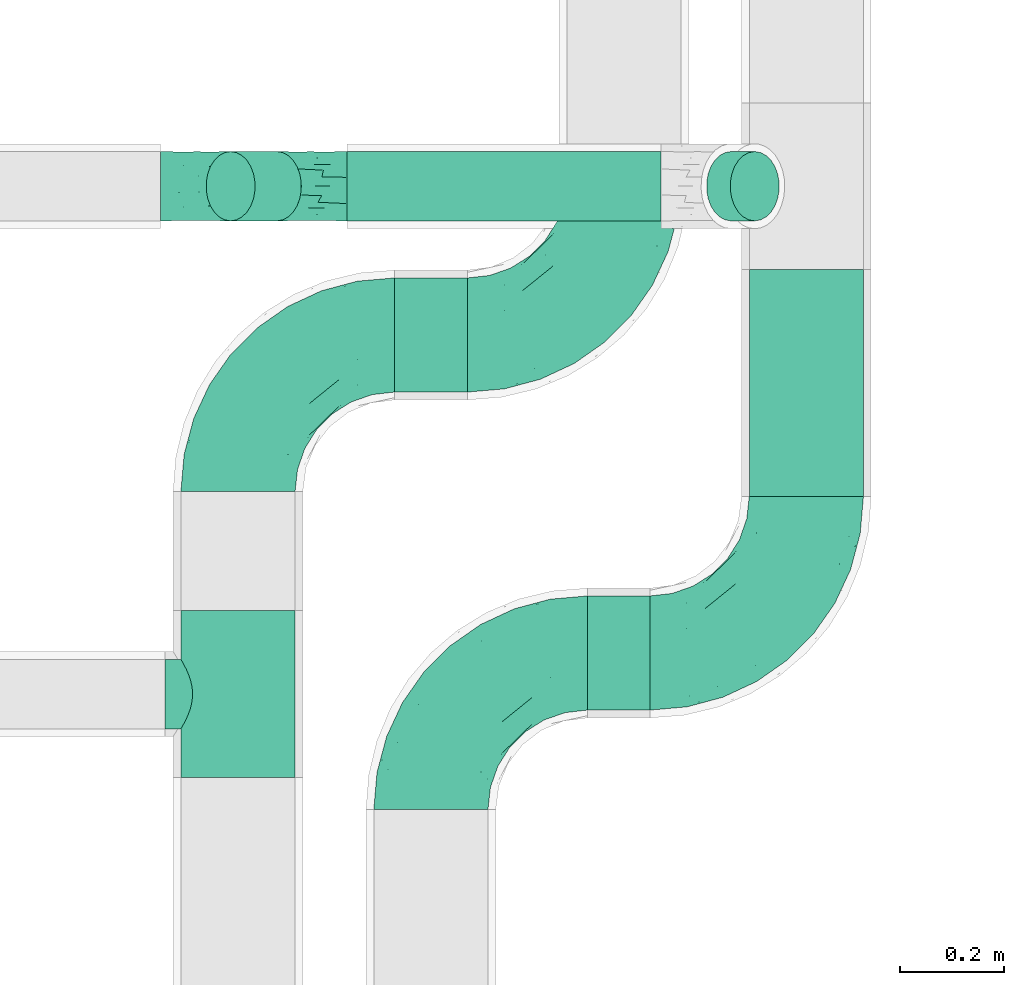
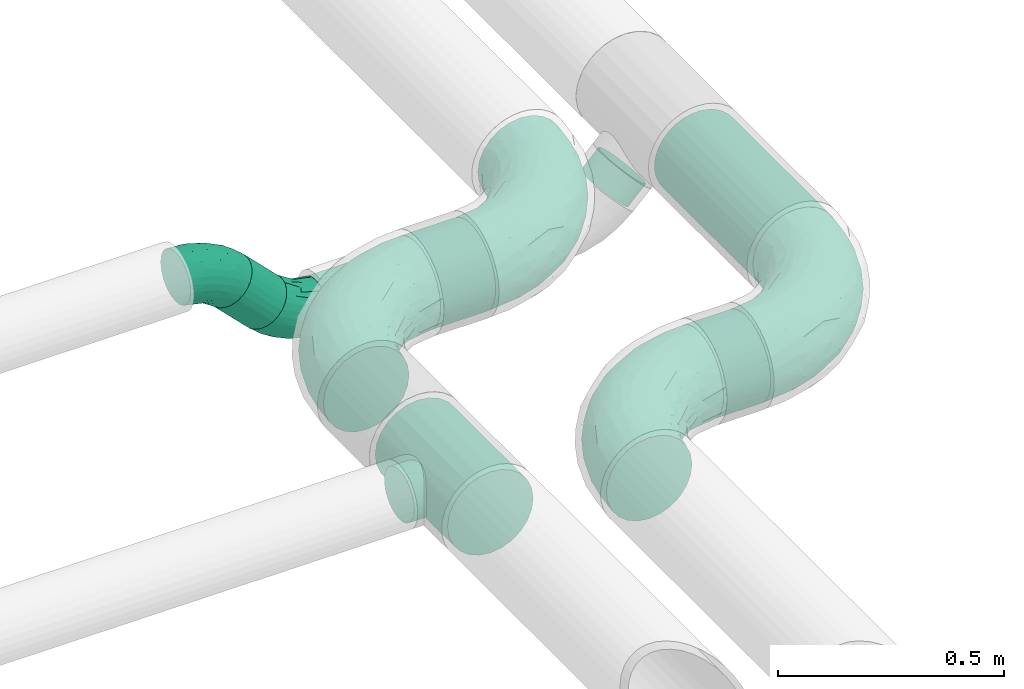
# One storey, part 73 of 93: 7 flow fittings, 6 flow segments.
"""IFC2X3 building model written with IfcOpenShell, lengths in millimetres."""

from ifc_helpers import new_model, entity, si_unit, converted_unit, derived_unit, direction, frame, origin, origin_2d_with_axis, place, context, subcontext, project, spatial, circle, extrude, faceted_brep, source, transform, mapped, material, type_object, type_shapes, element, save


model = new_model("IFC2X3")

# Units and contexts
model_context = context("Model", 3, precision=0.01, world=origin(), true_north=direction((6.12303176911189e-17, 1.0)))
body_context = subcontext(model_context, "Body", "Model", "MODEL_VIEW")
ifc_project = project(units=[si_unit("LENGTHUNIT", "METRE", prefix="MILLI"), si_unit("AREAUNIT", "SQUARE_METRE"), si_unit("VOLUMEUNIT", "CUBIC_METRE"), converted_unit("PLANEANGLEUNIT", "DEGREE", entity("IfcRatioMeasure", 0.0174532925199433), si_unit("PLANEANGLEUNIT", "RADIAN"), dimensions=[0, 0, 0, 0, 0, 0, 0]), si_unit("MASSUNIT", "GRAM", prefix="KILO"), derived_unit("MASSDENSITYUNIT", [(si_unit("MASSUNIT", "GRAM", prefix="KILO"), 1), (si_unit("LENGTHUNIT", "METRE"), -3)]), derived_unit("MOMENTOFINERTIAUNIT", [(si_unit("LENGTHUNIT", "METRE"), 4)]), si_unit("TIMEUNIT", "SECOND"), si_unit("FREQUENCYUNIT", "HERTZ"), si_unit("THERMODYNAMICTEMPERATUREUNIT", "DEGREE_CELSIUS"), derived_unit("THERMALTRANSMITTANCEUNIT", [(si_unit("MASSUNIT", "GRAM", prefix="KILO"), 1), (si_unit("THERMODYNAMICTEMPERATUREUNIT", "KELVIN"), -1), (si_unit("TIMEUNIT", "SECOND"), -3)]), derived_unit("VOLUMETRICFLOWRATEUNIT", [(si_unit("LENGTHUNIT", "METRE"), 3), (si_unit("TIMEUNIT", "SECOND"), -1)]), derived_unit("MASSFLOWRATEUNIT", [(si_unit("MASSUNIT", "GRAM", prefix="KILO"), 1), (si_unit("TIMEUNIT", "SECOND"), -1)]), derived_unit("ROTATIONALFREQUENCYUNIT", [(si_unit("TIMEUNIT", "SECOND"), -1)]), si_unit("ELECTRICCURRENTUNIT", "AMPERE"), si_unit("ELECTRICVOLTAGEUNIT", "VOLT"), si_unit("POWERUNIT", "WATT"), si_unit("FORCEUNIT", "NEWTON", prefix="KILO"), si_unit("ILLUMINANCEUNIT", "LUX"), si_unit("LUMINOUSFLUXUNIT", "LUMEN"), si_unit("LUMINOUSINTENSITYUNIT", "CANDELA"), derived_unit("USERDEFINED", [(si_unit("MASSUNIT", "GRAM", prefix="KILO"), -1), (si_unit("LENGTHUNIT", "METRE"), -2), (si_unit("TIMEUNIT", "SECOND"), 3), (si_unit("LUMINOUSFLUXUNIT", "LUMEN"), 1)]), derived_unit("LINEARVELOCITYUNIT", [(si_unit("LENGTHUNIT", "METRE"), 1), (si_unit("TIMEUNIT", "SECOND"), -1)]), si_unit("PRESSUREUNIT", "PASCAL"), derived_unit("USERDEFINED", [(si_unit("LENGTHUNIT", "METRE"), -2), (si_unit("MASSUNIT", "GRAM", prefix="KILO"), 1), (si_unit("TIMEUNIT", "SECOND"), -2)]), derived_unit("LINEARFORCEUNIT", [(si_unit("MASSUNIT", "GRAM", prefix="KILO"), 1), (si_unit("LENGTHUNIT", "METRE"), 1), (si_unit("TIMEUNIT", "SECOND"), -2), (si_unit("LENGTHUNIT", "METRE"), -1)]), derived_unit("PLANARFORCEUNIT", [(si_unit("MASSUNIT", "GRAM", prefix="KILO"), 1), (si_unit("LENGTHUNIT", "METRE"), 1), (si_unit("TIMEUNIT", "SECOND"), -2), (si_unit("LENGTHUNIT", "METRE"), -2)])], contexts=[model_context])

# Site, building, storey
site_placement = place(None, origin())
site = spatial("IfcSite", under=ifc_project, at=site_placement, CompositionType="ELEMENT")
building_placement = place(site_placement, origin())
building = spatial("IfcBuilding", under=site, at=building_placement, CompositionType="ELEMENT")
storey_placement = place(building_placement, frame((0.0, 0.0, -4200.0)))
storey = spatial("IfcBuildingStorey", under=building, at=storey_placement, CompositionType="ELEMENT", Elevation=-4200.0)

# Flow segments
pipe_segment_type = type_object("IfcPipeSegmentType", PredefinedType="NOTDEFINED")
flow_segment_1_placement = place(storey_placement, frame((31009.78, 8467.66, 2688.9)))
element("IfcFlowSegment", 1, at=flow_segment_1_placement, inside=storey, type_object=pipe_segment_type, context=body_context, shape_type="SweptSolid", body=[
    extrude(circle(Radius=109.5, at=origin_2d_with_axis()), frame((0.0, 111.1, 111.1), z_axis=(1.0, 0.0, 0.0), x_axis=(0.0, -1.0, 0.0)), (0.0, 0.0, 1.0), 120.218301649666),
])
flow_segment_2_placement = place(storey_placement, frame((30639.78, 9077.66, 2688.9)))
element("IfcFlowSegment", 2, at=flow_segment_2_placement, inside=storey, type_object=pipe_segment_type, context=body_context, shape_type="SweptSolid", body=[
    extrude(circle(Radius=109.5, at=origin_2d_with_axis()), frame((0.0, 111.1, 111.1), z_axis=(1.0, 0.0, 0.0), x_axis=(0.0, -1.0, 0.0)), (0.0, 0.0, 1.0), 140.218301649687),
])
flow_segment_3_placement = place(storey_placement, frame((31318.9, 8878.76, 2688.9)))
element("IfcFlowSegment", 3, at=flow_segment_3_placement, inside=storey, type_object=pipe_segment_type, context=body_context, shape_type="SweptSolid", body=[
    extrude(circle(Radius=109.5, at=origin_2d_with_axis()), frame((111.1, 0.0, 111.1), z_axis=(0.0, 1.0, 0.0), x_axis=(1.0, 0.0, 0.0)), (0.0, 0.0, 1.0), 435.378639737443),
])
flow_segment_4_placement = place(storey_placement, frame((30548.7, 9406.04, 2531.9)))
element("IfcFlowSegment", 4, at=flow_segment_4_placement, inside=storey, type_object=pipe_segment_type, context=body_context, shape_type="SweptSolid", body=[
    extrude(circle(Radius=66.5, at=origin_2d_with_axis()), frame((0.0, 68.1, 68.1), z_axis=(1.0, 0.0, 0.0), x_axis=(0.0, 1.0, 0.0)), (0.0, 0.0, 1.0), 602.598846298237),
])
flow_segment_5_placement = place(storey_placement, frame((31237.03, 9406.04, 2607.03)))
element("IfcFlowSegment", 5, at=flow_segment_5_placement, inside=storey, type_object=pipe_segment_type, context=body_context, shape_type="SweptSolid", body=[
    extrude(circle(Radius=66.5, at=origin_2d_with_axis()), frame((48.62, 68.1, 48.62), z_axis=(0.707106781186436, 0.0, 0.707106781186659), x_axis=(0.0, 1.0, 0.0)), (0.0, 0.0, 1.0), 64.1421356237339),
])
flow_segment_6_placement = place(storey_placement, frame((30277.03, 9406.04, 2607.03)))
element("IfcFlowSegment", 6, at=flow_segment_6_placement, inside=storey, type_object=pipe_segment_type, context=body_context, shape_type="SweptSolid", body=[
    extrude(circle(Radius=66.5, at=origin_2d_with_axis()), frame((137.32, 68.1, 48.62), z_axis=(-0.707106781186466, 0.0, 0.70710678118663), x_axis=(0.0, 1.0, 0.0)), (0.0, 0.0, 1.0), 125.44155877284),
])

# Flow fittings
ifc_material = material()
pipe_fitting_type_1 = type_object("IfcPipeFittingType", PredefinedType="NOTDEFINED", material=ifc_material)
shared_shape_1 = source(origin(), body_context, "Body", "Brep", [
    faceted_brep([(-300.0, 54.75, -94.83), (-300.0, 28.34, -105.77), (-300.0, 0.0, -109.5), (-300.0, -28.34, -105.77), (-300.0, -54.75, -94.83), (-300.0, -77.43, -77.43), (-300.0, -94.83, -54.75), (-300.0, -105.77, -28.34), (-300.0, -109.5, 0.0), (-300.0, -105.77, 28.34), (-300.0, -94.83, 54.75), (-300.0, -77.43, 77.43), (-300.0, -54.75, 94.83), (-300.0, -28.34, 105.77), (-300.0, 0.0, 109.5), (-300.0, 28.34, 105.77), (-300.0, 54.75, 94.83), (-300.0, 77.43, 77.43), (-300.0, 94.83, 54.75), (-300.0, 105.77, 28.34), (-300.0, 109.5, 0.0), (-300.0, 105.77, -28.34), (-300.0, 94.83, -54.75), (-300.0, 77.43, -77.43), (0.0, 300.0, -109.5), (-28.34, 300.0, -105.77), (-54.75, 300.0, -94.83), (-77.43, 300.0, -77.43), (-94.83, 300.0, -54.75), (-105.77, 300.0, -28.34), (-109.5, 300.0, 0.0), (-105.77, 300.0, 28.34), (-94.83, 300.0, 54.75), (-77.43, 300.0, 77.43), (-54.75, 300.0, 94.83), (-28.34, 300.0, 105.77), (0.0, 300.0, 109.5), (28.34, 300.0, 105.77), (54.75, 300.0, 94.83), (77.43, 300.0, 77.43), (94.83, 300.0, 54.75), (105.77, 300.0, 28.34), (109.5, 300.0, 0.0), (105.77, 300.0, -28.34), (94.83, 300.0, -54.75), (77.43, 300.0, -77.43), (54.75, 300.0, -94.83), (28.34, 300.0, -105.77), (-136.7, 192.11, 33.4), (-108.06, 242.04, 45.72), (-115.25, 243.91, 23.63), (-228.89, -103.28, 0.0), (-205.72, -93.9, 30.98), (-223.48, -82.05, 62.89), (82.05, 223.48, 62.89), (-220.42, -37.16, 99.17), (-129.13, -11.54, 94.5), (-142.05, 16.57, 106.73), (-36.78, -13.7, 0.0), (-12.01, 12.01, 21.92), (-70.11, -34.19, 28.86), (-251.45, -65.77, 85.04), (25.82, 74.91, 52.65), (64.71, 143.75, 51.25), (23.5, 97.93, 73.21), (-132.85, -71.12, 23.16), (-159.94, -84.8, 0.0), (-95.25, -54.64, 0.0), (-96.13, 227.29, 70.78), (-125.84, 193.4, 53.02), (-74.91, -25.82, 52.65), (-17.67, 17.67, 46.21), (-143.75, -64.71, 51.25), (34.19, 70.11, 28.86), (-36.83, 151.15, 109.47), (-72.47, 101.01, 109.48), (-16.57, 142.05, 106.73), (-230.69, 46.79, 102.89), (-151.06, 181.23, 0.0), (-193.02, 137.32, 30.03), (-245.74, 114.87, 22.86), (-217.35, 128.37, 0.0), (-257.61, 114.28, 0.0), (-206.97, 23.39, 109.2), (-228.54, -10.67, 107.88), (-63.53, 63.53, 103.95), (-152.02, 152.02, 61.3), (-239.14, 108.86, 45.92), (-46.79, 230.69, 102.89), (-23.39, 206.97, 109.2), (-187.96, -54.73, 82.5), (13.7, 36.78, 0.0), (54.64, 95.25, 0.0), (-252.51, 68.8, 88.87), (10.67, 228.54, 107.88), (37.16, 220.42, 99.17), (-156.91, 87.58, 100.32), (-167.17, 59.01, 106.65), (103.28, 228.89, 0.0), (93.9, 205.72, 30.98), (84.8, 159.94, 0.0), (-63.56, 159.75, 106.59), (71.12, 132.85, 23.16), (-142.71, 44.43, 109.5), (63.87, 170.82, 67.63), (65.77, 251.45, 85.04), (54.73, 187.96, 82.5), (11.54, 129.13, 94.5), (-114.28, 257.61, 0.0), (-128.37, 217.35, 0.0), (-181.23, 151.06, 0.0), (-229.13, 95.58, 70.67), (-69.3, 249.25, 89.01), (-87.17, 189.36, 91.52), (-119.64, 123.85, 98.47), (-114.16, 102.69, 105.6), (-97.93, -23.5, 73.21), (-38.98, 38.98, 84.91), (-76.05, 27.59, 96.01), (-136.12, 132.19, 87.79), (-194.78, 84.82, 91.29), (-38.49, 15.54, 67.27), (-119.57, 181.27, 70.23), (-177.11, 114.75, 77.16), (-196.39, 119.69, 59.32), (-29.77, 73.43, 96.01), (-68.81, 187.42, 100.76), (-170.82, -63.87, 67.63), (-242.04, 108.06, -45.72), (-243.91, 115.25, -23.63), (-99.47, 217.21, -71.36), (-202.49, 24.61, -109.22), (-224.29, -9.94, -107.83), (-12.01, 12.01, -21.92), (34.19, 70.11, -28.86), (-243.92, 70.22, -89.23), (-224.05, 97.15, -70.96), (-70.11, -34.19, -28.86), (37.16, 220.42, -99.17), (-137.32, 193.02, -30.03), (-192.11, 136.7, -33.4), (-9.56, 157.76, -106.97), (9.82, 126.4, -94.6), (-26.99, 75.01, -95.39), (-108.86, 239.14, -45.92), (-121.71, 195.15, -57.54), (-193.4, 125.84, -53.02), (-168.29, 120.23, -77.72), (-131.44, 156.1, -76.48), (-114.09, 152.67, -89.71), (-58.82, 66.26, -103.46), (-72.9, 29.97, -95.91), (-148.76, 21.01, -108.12), (-235.23, -39.46, -99.56), (-209.2, -59.7, -83.37), (25.86, 75.0, -52.68), (-17.67, 17.67, -46.21), (-224.25, -82.18, -62.93), (-205.72, -93.9, -30.98), (-160.57, -20.91, -97.48), (-111.76, -26.64, -77.85), (71.12, 132.85, -23.16), (64.71, 143.75, -51.25), (93.9, 205.72, -30.98), (-132.85, -71.12, -23.16), (23.46, 97.98, -73.28), (-39.51, 14.6, -67.27), (-157.82, 65.68, -106.39), (-100.24, 111.65, -106.5), (-108.02, 70.62, -109.5), (-229.63, 47.01, -102.91), (-77.16, -26.73, -53.6), (-143.75, -64.71, -51.25), (-114.87, 245.74, -22.86), (-21.27, 215.47, -109.15), (-65.44, 173.68, -104.22), (-44.92, 240.82, -102.64), (-152.02, 152.02, -61.3), (11.39, 233.1, -107.93), (65.77, 251.45, -85.04), (-72.39, 233.4, -89.67), (-38.98, 38.98, -84.91), (-52.88, 131.78, -109.49), (-180.51, 91.33, -91.9), (82.05, 223.48, -62.89), (54.73, 187.96, -82.5), (-153.65, 46.01, -109.28), (-131.22, 111.56, -98.89), (-160.99, -57.92, -70.28), (63.87, 170.82, -67.63)], [[[0, 1, 2, 3, 4, 5, 6, 7, 8, 9, 10, 11, 12, 13, 14, 15, 16, 17, 18, 19, 20, 21, 22, 23]], [[24, 25, 26, 27, 28, 29, 30, 31, 32, 33, 34, 35, 36, 37, 38, 39, 40, 41, 42, 43, 44, 45, 46, 47]], [[48, 49, 50]], [[9, 51, 52]], [[10, 53, 11]], [[9, 52, 10]], [[39, 54, 40]], [[55, 56, 57]], [[9, 8, 51]], [[58, 59, 60]], [[11, 61, 12]], [[62, 63, 64]], [[65, 66, 67]], [[68, 49, 69]], [[58, 60, 67]], [[52, 51, 66]], [[55, 12, 61]], [[70, 60, 71]], [[65, 72, 52]], [[71, 73, 62]], [[74, 75, 76]], [[77, 16, 15]], [[49, 31, 50]], [[78, 79, 48]], [[80, 81, 82]], [[14, 83, 15]], [[14, 13, 84]], [[75, 85, 76]], [[48, 79, 86]], [[80, 87, 79]], [[84, 13, 55]], [[20, 19, 80]], [[20, 80, 82]], [[35, 88, 89]], [[53, 90, 61]], [[91, 92, 73]], [[16, 93, 17]], [[87, 19, 18]], [[58, 91, 59]], [[89, 36, 35]], [[94, 95, 37]], [[96, 77, 97]], [[98, 99, 100]], [[101, 75, 74]], [[99, 98, 41]], [[102, 73, 92]], [[83, 103, 97]], [[94, 76, 95]], [[63, 73, 102]], [[99, 40, 54]], [[104, 63, 54]], [[105, 39, 38]], [[52, 72, 53]], [[65, 67, 60]], [[40, 99, 41]], [[42, 41, 98]], [[35, 34, 88]], [[106, 95, 107]], [[50, 30, 108]], [[109, 48, 50]], [[77, 15, 83]], [[78, 110, 79]], [[111, 17, 93]], [[95, 106, 105]], [[68, 33, 32]], [[48, 109, 78]], [[12, 55, 13]], [[89, 88, 101]], [[110, 81, 79]], [[112, 68, 113]], [[17, 111, 18]], [[114, 96, 115]], [[116, 117, 118]], [[112, 34, 33]], [[107, 64, 106]], [[96, 119, 120]], [[95, 38, 37]], [[73, 71, 59]], [[92, 100, 102]], [[121, 117, 116]], [[49, 32, 31]], [[68, 69, 122]], [[123, 120, 119]], [[124, 79, 87]], [[56, 55, 90]], [[84, 57, 83]], [[116, 56, 90]], [[56, 116, 118]], [[37, 36, 94]], [[107, 95, 76]], [[125, 76, 85]], [[107, 125, 64]], [[112, 88, 34]], [[114, 101, 126]], [[97, 77, 83]], [[93, 77, 120]], [[52, 53, 10]], [[127, 53, 72]], [[54, 39, 105]], [[99, 54, 63]], [[100, 99, 102]], [[63, 102, 99]], [[72, 65, 60]], [[52, 66, 65]], [[127, 116, 90]], [[72, 60, 70]], [[64, 117, 121]], [[104, 64, 63]], [[57, 84, 55]], [[83, 14, 84]], [[36, 89, 94]], [[94, 89, 74]], [[18, 111, 87]], [[124, 87, 111]], [[73, 59, 91]], [[60, 59, 71]], [[126, 101, 88]], [[101, 115, 75]], [[115, 97, 103]], [[75, 103, 85]], [[118, 57, 56]], [[85, 118, 125]], [[69, 49, 48]], [[68, 32, 49]], [[83, 57, 103]], [[96, 97, 115]], [[85, 103, 57]], [[115, 103, 75]], [[30, 50, 31]], [[109, 50, 108]], [[68, 112, 33]], [[112, 113, 126]], [[96, 114, 119]], [[77, 96, 120]], [[122, 113, 68]], [[86, 124, 123]], [[101, 114, 115]], [[113, 119, 114]], [[77, 93, 16]], [[111, 93, 120]], [[121, 70, 71]], [[72, 70, 116]], [[63, 62, 73]], [[121, 62, 64]], [[87, 80, 19]], [[81, 80, 79]], [[53, 61, 11]], [[55, 61, 90]], [[95, 105, 38]], [[54, 105, 106]], [[116, 127, 72]], [[90, 53, 127]], [[54, 106, 104]], [[64, 104, 106]], [[70, 121, 116]], [[121, 71, 62]], [[123, 124, 111]], [[79, 124, 86]], [[120, 123, 111]], [[86, 123, 119]], [[112, 126, 88]], [[114, 126, 113]], [[94, 74, 76]], [[101, 74, 89]], [[125, 118, 117]], [[57, 118, 85]], [[64, 125, 117]], [[76, 125, 107]], [[48, 86, 69]], [[69, 86, 122]], [[86, 119, 122]], [[113, 122, 119]], [[128, 21, 129]], [[130, 28, 27]], [[2, 1, 131]], [[2, 131, 132]], [[91, 133, 134]], [[0, 23, 135]], [[136, 23, 22]], [[58, 67, 137]], [[82, 129, 20]], [[46, 138, 47]], [[139, 110, 78]], [[129, 81, 140]], [[141, 142, 143]], [[140, 81, 110]], [[144, 145, 139]], [[136, 128, 146]], [[147, 148, 149]], [[150, 151, 152]], [[153, 154, 4]], [[155, 134, 156]], [[157, 158, 6]], [[5, 157, 6]], [[159, 151, 160]], [[8, 7, 51]], [[154, 5, 4]], [[161, 162, 163]], [[164, 137, 67]], [[2, 132, 3]], [[165, 155, 166]], [[7, 158, 51]], [[66, 51, 158]], [[159, 160, 154]], [[167, 168, 169]], [[137, 156, 133]], [[1, 0, 170]], [[140, 128, 129]], [[78, 109, 139]], [[171, 137, 172]], [[156, 137, 171]], [[144, 29, 28]], [[30, 173, 108]], [[174, 175, 176]], [[173, 30, 29]], [[177, 140, 139]], [[157, 5, 154]], [[173, 144, 139]], [[174, 25, 24]], [[170, 131, 1]], [[178, 24, 47]], [[46, 179, 138]], [[167, 131, 170]], [[25, 176, 26]], [[173, 109, 108]], [[27, 180, 130]], [[165, 181, 143]], [[150, 182, 141]], [[92, 161, 100]], [[134, 92, 91]], [[183, 135, 136]], [[3, 153, 4]], [[98, 100, 163]], [[138, 142, 141]], [[91, 58, 133]], [[179, 46, 45]], [[44, 43, 163]], [[163, 162, 184]], [[42, 98, 43]], [[172, 137, 164]], [[6, 158, 7]], [[43, 98, 163]], [[161, 92, 134]], [[45, 44, 184]], [[180, 27, 26]], [[184, 185, 179]], [[130, 180, 149]], [[139, 140, 110]], [[67, 66, 164]], [[131, 152, 132]], [[178, 174, 24]], [[182, 169, 168]], [[128, 22, 21]], [[147, 183, 136]], [[142, 138, 185]], [[178, 138, 141]], [[165, 142, 185]], [[142, 165, 143]], [[150, 143, 151]], [[182, 150, 169]], [[135, 170, 0]], [[186, 167, 169]], [[131, 186, 152]], [[153, 132, 159]], [[176, 180, 26]], [[187, 175, 168]], [[175, 149, 180]], [[149, 183, 147]], [[171, 166, 156]], [[188, 154, 160]], [[163, 184, 44]], [[189, 184, 162]], [[66, 158, 164]], [[172, 164, 158]], [[162, 161, 134]], [[163, 100, 161]], [[188, 157, 154]], [[158, 157, 172]], [[189, 165, 185]], [[162, 134, 155]], [[28, 130, 144]], [[145, 144, 130]], [[137, 133, 58]], [[134, 133, 156]], [[170, 183, 167]], [[183, 149, 187]], [[150, 152, 169]], [[159, 132, 152]], [[138, 178, 47]], [[174, 178, 141]], [[167, 183, 187]], [[182, 175, 174]], [[175, 182, 168]], [[174, 141, 182]], [[146, 128, 140]], [[136, 22, 128]], [[132, 153, 3]], [[154, 153, 159]], [[174, 176, 25]], [[180, 176, 175]], [[136, 135, 23]], [[170, 135, 183]], [[20, 129, 21]], [[81, 129, 82]], [[188, 171, 172]], [[166, 160, 181]], [[160, 166, 171]], [[165, 166, 181]], [[166, 155, 156]], [[162, 155, 165]], [[144, 173, 29]], [[109, 173, 139]], [[184, 179, 45]], [[138, 179, 185]], [[146, 147, 136]], [[147, 177, 148]], [[145, 148, 177]], [[130, 149, 148]], [[151, 143, 181]], [[141, 143, 150]], [[160, 151, 181]], [[152, 151, 159]], [[171, 188, 160]], [[157, 188, 172]], [[165, 189, 162]], [[185, 184, 189]], [[148, 145, 130]], [[139, 145, 177]], [[152, 186, 169]], [[131, 167, 186]], [[175, 187, 149]], [[167, 187, 168]], [[140, 177, 146]], [[146, 177, 147]]]),
])
type_shapes(pipe_fitting_type_1, [shared_shape_1])
flow_fitting_1_placement = place(storey_placement, frame((30709.78, 8578.76, 2800.0), z_axis=(0.0, 0.0, 1.0), x_axis=(-1.0, 0.0, 0.0)))
element("IfcFlowFitting", 7, at=flow_fitting_1_placement, inside=storey, type_object=pipe_fitting_type_1, material=ifc_material, context=body_context, shape_type="MappedRepresentation", body=[
    mapped(shared_shape_1, transform((0.0, 0.0, 0.0), scale=1.0)),
])
flow_fitting_2_placement = place(storey_placement, frame((31430.0, 8578.76, 2800.0)))
element("IfcFlowFitting", 8, at=flow_fitting_2_placement, inside=storey, type_object=pipe_fitting_type_1, material=ifc_material, context=body_context, shape_type="MappedRepresentation", body=[
    mapped(shared_shape_1, transform((0.0, 0.0, 0.0), scale=1.0)),
])
flow_fitting_3_placement = place(storey_placement, frame((30339.78, 9188.76, 2800.0), z_axis=(0.0, 0.0, 1.0), x_axis=(-1.0, 0.0, 0.0)))
element("IfcFlowFitting", 9, at=flow_fitting_3_placement, inside=storey, type_object=pipe_fitting_type_1, material=ifc_material, context=body_context, shape_type="MappedRepresentation", body=[
    mapped(shared_shape_1, transform((0.0, 0.0, 0.0), scale=1.0)),
])
flow_fitting_4_placement = place(storey_placement, frame((31080.0, 9188.76, 2800.0)))
element("IfcFlowFitting", 10, at=flow_fitting_4_placement, inside=storey, type_object=pipe_fitting_type_1, material=ifc_material, context=body_context, shape_type="MappedRepresentation", body=[
    mapped(shared_shape_1, transform((0.0, 0.0, 0.0), scale=1.0)),
])
pipe_fitting_type_2 = type_object("IfcPipeFittingType", PredefinedType="NOTDEFINED", material=ifc_material)
shared_shape_2 = source(origin(), body_context, "Body", "Brep", [
    faceted_brep([(-160.0, 0.0, -109.5), (-160.0, -28.34, -105.77), (-160.0, -54.75, -94.83), (-160.0, -77.43, -77.43), (-160.0, -94.83, -54.75), (-160.0, -100.3, -41.55), (-160.0, -105.77, -28.34), (-160.0, -107.63, -14.17), (-160.0, -109.5, 0.0), (-160.0, -107.63, 14.17), (-160.0, -105.77, 28.34), (-160.0, -100.3, 41.55), (-160.0, -94.83, 54.75), (-160.0, -77.43, 77.43), (-160.0, -54.75, 94.83), (-160.0, -28.34, 105.77), (-160.0, 0.0, 109.5), (-160.0, 28.34, 105.77), (-160.0, 54.75, 94.83), (-160.0, 77.43, 77.43), (-160.0, 94.83, 54.75), (-160.0, 105.77, 28.34), (-160.0, 109.5, 0.0), (-160.0, 105.77, -28.34), (-160.0, 94.83, -54.75), (-160.0, 77.43, -77.43), (-160.0, 54.75, -94.83), (-160.0, 28.34, -105.77), (160.0, 28.34, -105.77), (160.0, 54.75, -94.83), (160.0, 77.43, -77.43), (160.0, 94.83, -54.75), (160.0, 105.77, -28.34), (160.0, 109.5, 0.0), (160.0, 105.77, 28.34), (160.0, 94.83, 54.75), (160.0, 77.43, 77.43), (160.0, 54.75, 94.83), (160.0, 28.34, 105.77), (160.0, 0.0, 109.5), (160.0, -28.34, 105.77), (160.0, -54.75, 94.83), (160.0, -77.43, 77.43), (160.0, -94.83, 54.75), (160.0, -100.3, 41.55), (160.0, -105.77, 28.34), (160.0, -107.63, 14.17), (160.0, -109.5, 0.0), (160.0, -107.63, -14.17), (160.0, -105.77, -28.34), (160.0, -100.3, -41.55), (160.0, -94.83, -54.75), (160.0, -77.43, -77.43), (160.0, -54.75, -94.83), (160.0, -28.34, -105.77), (160.0, 0.0, -109.5), (61.24, -106.39, 25.91), (65.16, -108.69, 13.3), (66.5, -109.5, 0.0), (55.06, -102.95, 37.29), (46.93, -98.84, 47.12), (37.11, -94.58, 55.18), (25.81, -90.74, 61.29), (-61.25, -106.39, 25.91), (-65.16, -108.69, 13.3), (-66.5, -109.5, 0.0), (-55.06, -102.96, 37.29), (-25.83, -90.75, 61.28), (-37.12, -94.58, 55.18), (-46.93, -98.85, 47.11), (-13.3, -88.01, 65.16), (-0.01, -86.99, 66.5), (13.28, -88.0, 65.16), (-0.01, -86.99, -66.5), (-13.3, -88.01, -65.16), (13.28, -88.0, -65.16), (46.93, -98.84, -47.12), (37.11, -94.58, -55.18), (-55.06, -102.96, -37.29), (25.81, -90.74, -61.29), (61.24, -106.39, -25.91), (65.16, -108.69, -13.3), (55.06, -102.95, -37.29), (-25.83, -90.75, -61.28), (-37.12, -94.58, -55.18), (-46.93, -98.85, -47.11), (-65.16, -108.69, -13.3), (-61.25, -106.39, -25.91), (0.0, -140.0, -66.5), (17.21, -140.0, -64.23), (33.25, -140.0, -57.59), (47.02, -140.0, -47.02), (57.59, -140.0, -33.25), (64.23, -140.0, -17.21), (66.5, -140.0, 0.0), (64.23, -140.0, 17.21), (57.59, -140.0, 33.25), (47.02, -140.0, 47.02), (33.25, -140.0, 57.59), (17.21, -140.0, 64.23), (0.0, -140.0, 66.5), (-17.21, -140.0, 64.23), (-33.25, -140.0, 57.59), (-47.02, -140.0, 47.02), (-57.59, -140.0, 33.25), (-64.23, -140.0, 17.21), (-66.5, -140.0, 0.0), (-64.23, -140.0, -17.21), (-57.59, -140.0, -33.25), (-47.02, -140.0, -47.02), (-33.25, -140.0, -57.59), (-17.21, -140.0, -64.23)], [[[0, 1, 2, 3, 4, 5, 6, 7, 8, 9, 10, 11, 12, 13, 14, 15, 16, 17, 18, 19, 20, 21, 22, 23, 24, 25, 26, 27]], [[28, 29, 30, 31, 32, 33, 34, 35, 36, 37, 38, 39, 40, 41, 42, 43, 44, 45, 46, 47, 48, 49, 50, 51, 52, 53, 54, 55]], [[45, 56, 46]], [[57, 58, 47]], [[57, 46, 56]], [[45, 59, 56]], [[44, 60, 59]], [[60, 44, 43]], [[61, 60, 43]], [[62, 61, 43]], [[63, 9, 64]], [[59, 45, 44]], [[63, 10, 9]], [[64, 8, 65]], [[8, 64, 9]], [[63, 66, 10]], [[12, 67, 13]], [[68, 67, 12]], [[69, 12, 11]], [[12, 69, 68]], [[66, 11, 10]], [[67, 70, 13]], [[57, 47, 46]], [[62, 43, 42]], [[15, 14, 41, 40]], [[71, 72, 42]], [[42, 72, 62]], [[41, 14, 13, 42]], [[16, 15, 40, 39]], [[20, 19, 36, 35]], [[21, 20, 35, 34]], [[18, 17, 38, 37]], [[19, 18, 37, 36]], [[38, 17, 16, 39]], [[22, 21, 34, 33]], [[13, 70, 71]], [[71, 42, 13]], [[69, 11, 66]], [[25, 24, 31, 30]], [[23, 22, 33, 32]], [[31, 24, 23, 32]], [[26, 25, 30, 29]], [[54, 53, 2, 1]], [[0, 27, 28, 55]], [[1, 0, 55, 54]], [[29, 28, 27, 26]], [[3, 2, 53, 52]], [[73, 74, 3]], [[3, 52, 73]], [[52, 75, 73]], [[51, 76, 77]], [[51, 50, 76]], [[78, 6, 5]], [[75, 52, 79]], [[77, 79, 51]], [[80, 48, 81]], [[79, 52, 51]], [[81, 48, 47]], [[81, 47, 58]], [[80, 82, 49]], [[80, 49, 48]], [[49, 82, 50]], [[83, 4, 3]], [[76, 50, 82]], [[84, 85, 4]], [[85, 78, 5]], [[84, 4, 83]], [[83, 3, 74]], [[86, 7, 87]], [[78, 87, 6]], [[7, 6, 87]], [[8, 86, 65]], [[5, 4, 85]], [[86, 8, 7]], [[88, 89, 90, 91, 92, 93, 94, 95, 96, 97, 98, 99, 100, 101, 102, 103, 104, 105, 106, 107, 108, 109, 110, 111]], [[65, 106, 64]], [[105, 64, 106]], [[66, 104, 103]], [[68, 103, 102]], [[105, 104, 63]], [[67, 102, 101]], [[63, 64, 105]], [[66, 103, 69]], [[104, 66, 63]], [[68, 102, 67]], [[70, 67, 101]], [[69, 103, 68]], [[100, 71, 70]], [[70, 101, 100]], [[99, 72, 100]], [[98, 62, 99]], [[96, 95, 56]], [[96, 59, 97]], [[61, 98, 97]], [[57, 95, 94]], [[62, 98, 61]], [[72, 99, 62]], [[97, 60, 61]], [[58, 57, 94]], [[56, 59, 96]], [[57, 56, 95]], [[97, 59, 60]], [[100, 72, 71]], [[93, 81, 94]], [[92, 80, 93]], [[92, 91, 82]], [[89, 88, 75]], [[91, 90, 77]], [[79, 90, 89]], [[81, 58, 94]], [[82, 80, 92]], [[81, 93, 80]], [[76, 91, 77]], [[79, 77, 90]], [[82, 91, 76]], [[79, 89, 75]], [[88, 73, 75]], [[110, 83, 111]], [[109, 84, 110]], [[86, 107, 106]], [[109, 108, 78]], [[107, 87, 108]], [[65, 86, 106]], [[74, 111, 83]], [[88, 74, 73]], [[110, 84, 83]], [[86, 87, 107]], [[84, 109, 85]], [[85, 109, 78]], [[108, 87, 78]], [[74, 88, 111]]]),
])
type_shapes(pipe_fitting_type_2, [shared_shape_2])
flow_fitting_5_placement = place(storey_placement, frame((30339.78, 8500.0, 2800.0), z_axis=(0.0, 0.0, 1.0), x_axis=(0.0, -1.0, 0.0)))
element("IfcFlowFitting", 11, at=flow_fitting_5_placement, inside=storey, type_object=pipe_fitting_type_2, material=ifc_material, context=body_context, shape_type="MappedRepresentation", body=[
    mapped(shared_shape_2, transform((0.0, 0.0, 0.0), scale=1.0)),
])
pipe_fitting_type_3 = type_object("IfcPipeFittingType", PredefinedType="NOTDEFINED", material=ifc_material)
shared_shape_3 = source(origin(), body_context, "Body", "Brep", [
    faceted_brep([(-78.7, 33.25, -57.59), (-78.7, 17.21, -64.23), (-78.7, 0.0, -66.5), (-78.7, -17.21, -64.23), (-78.7, -33.25, -57.59), (-78.7, -47.02, -47.02), (-78.7, -57.59, -33.25), (-78.7, -64.23, -17.21), (-78.7, -66.5, 0.0), (-78.7, -64.23, 17.21), (-78.7, -57.59, 33.25), (-78.7, -47.02, 47.02), (-78.7, -33.25, 57.59), (-78.7, -17.21, 64.23), (-78.7, 0.0, 66.5), (-78.7, 17.21, 64.23), (-78.7, 33.25, 57.59), (-78.7, 47.02, 47.02), (-78.7, 57.59, 33.25), (-78.7, 64.23, 17.21), (-78.7, 66.5, 0.0), (-78.7, 64.23, -17.21), (-78.7, 57.59, -33.25), (-78.7, 47.02, -47.02), (55.65, 55.65, -66.5), (43.48, 67.82, -64.23), (32.14, 79.16, -57.59), (22.4, 88.9, -47.02), (14.93, 96.37, -33.25), (10.23, 101.07, -17.21), (8.63, 102.67, 0.0), (10.23, 101.07, 17.21), (14.93, 96.37, 33.25), (22.4, 88.9, 47.02), (32.14, 79.16, 57.59), (43.48, 67.82, 64.23), (55.65, 55.65, 66.5), (67.82, 43.48, 64.23), (79.16, 32.14, 57.59), (88.9, 22.4, 47.02), (96.37, 14.93, 33.25), (101.07, 10.23, 17.21), (102.67, 8.63, 0.0), (101.07, 10.23, -17.21), (96.37, 14.93, -33.25), (88.9, 22.4, -47.02), (79.16, 32.14, -57.59), (67.82, 43.48, -64.23), (-40.01, -57.38, 27.86), (-40.6, -61.75, 15.74), (-6.41, -52.87, 20.07), (-28.66, -61.57, 0.0), (44.74, 12.16, 61.0), (-23.71, -35.12, 51.77), (8.73, -21.07, 54.25), (-40.23, -23.04, 61.0), (-34.61, -49.5, 39.47), (-28.9, -3.87, 65.72), (-8.47, 20.45, 66.18), (-47.15, 10.46, 66.05), (-49.81, 55.22, 41.25), (-33.77, 66.88, 30.79), (-20.88, 50.42, 53.92), (7.4, 48.4, 61.91), (-34.71, 30.07, 61.97), (42.4, -35.06, 11.04), (19.46, -46.98, 0.0), (63.8, -23.27, 0.0), (-15.18, 67.35, 41.6), (14.82, -35.78, 38.27), (53.98, -24.32, 23.88), (-30.55, 73.76, 17.41), (-46.74, 70.71, 0.0), (59.47, -10.53, 39.47), (-16.95, 83.05, 0.0), (25.95, 40.74, 66.05), (41.59, -8.07, 51.77), (23.18, 17.7, 65.72), (74.36, -14.41, 12.26), (4.62, -11.15, 60.44), (-39.45, 28.99, -61.91), (-20.88, 50.42, -53.92), (3.28, 45.81, -61.97), (-23.41, 71.18, -30.79), (8.73, -21.07, -54.25), (4.62, -11.15, -60.44), (44.74, 12.16, -61.0), (-30.55, 73.76, -17.41), (-40.23, -23.04, -61.0), (-23.71, -35.12, -51.77), (-36.89, 58.36, -41.6), (-47.15, 10.46, -66.05), (-28.9, -3.87, -65.72), (-20.98, -55.37, -23.88), (-34.61, -49.5, -39.47), (68.86, -12.28, -27.86), (59.47, -10.53, -39.47), (-42.39, -62.77, -12.26), (41.59, -8.07, -51.77), (14.82, -35.78, -38.27), (41.92, -32.85, -20.07), (-5.19, -54.78, -11.04), (72.37, -14.95, -15.74), (-3.83, 74.27, -41.25), (25.95, 40.74, -66.05), (23.18, 17.7, -65.72), (-8.47, 20.45, -66.18)], [[[0, 1, 2, 3, 4, 5, 6, 7, 8, 9, 10, 11, 12, 13, 14, 15, 16, 17, 18, 19, 20, 21, 22, 23]], [[24, 25, 26, 27, 28, 29, 30, 31, 32, 33, 34, 35, 36, 37, 38, 39, 40, 41, 42, 43, 44, 45, 46, 47]], [[48, 49, 50]], [[49, 8, 51]], [[38, 37, 52]], [[12, 11, 53]], [[53, 54, 55]], [[56, 11, 10]], [[14, 13, 57]], [[13, 12, 55]], [[57, 58, 59]], [[60, 61, 18]], [[62, 63, 34]], [[18, 61, 19]], [[16, 15, 64]], [[17, 16, 62]], [[65, 66, 67]], [[60, 62, 68]], [[15, 14, 59]], [[34, 33, 62]], [[69, 50, 70]], [[19, 71, 72]], [[40, 39, 73]], [[72, 20, 19]], [[74, 71, 31]], [[50, 66, 65]], [[62, 16, 64]], [[56, 48, 69]], [[66, 50, 51]], [[36, 35, 75]], [[39, 38, 76]], [[76, 73, 39]], [[32, 31, 61]], [[75, 77, 36]], [[70, 41, 40]], [[77, 37, 36]], [[48, 56, 10]], [[70, 40, 73]], [[59, 64, 15]], [[76, 38, 52]], [[58, 75, 63]], [[42, 41, 78]], [[53, 56, 69]], [[17, 60, 18]], [[54, 79, 55]], [[72, 71, 74]], [[48, 9, 49]], [[30, 74, 31]], [[54, 69, 76]], [[31, 71, 61]], [[58, 57, 77]], [[32, 68, 33]], [[55, 57, 13]], [[68, 62, 33]], [[79, 52, 77]], [[35, 34, 63]], [[63, 62, 64]], [[73, 76, 69]], [[79, 77, 57]], [[78, 70, 65]], [[70, 73, 69]], [[56, 53, 11]], [[58, 63, 64]], [[53, 55, 12]], [[57, 55, 79]], [[77, 52, 37]], [[52, 79, 54]], [[57, 59, 14]], [[64, 59, 58]], [[63, 75, 35]], [[77, 75, 58]], [[62, 60, 17]], [[61, 60, 68]], [[32, 61, 68]], [[61, 71, 19]], [[9, 48, 10]], [[69, 48, 50]], [[8, 49, 9]], [[51, 50, 49]], [[78, 65, 67]], [[50, 65, 70]], [[42, 78, 67]], [[70, 78, 41]], [[69, 54, 53]], [[52, 54, 76]], [[1, 0, 80]], [[81, 82, 80]], [[28, 83, 29]], [[23, 81, 0]], [[20, 72, 21]], [[84, 85, 86]], [[21, 87, 83]], [[88, 89, 4]], [[81, 23, 90]], [[91, 92, 2]], [[26, 25, 82]], [[91, 2, 1]], [[93, 6, 94]], [[95, 96, 44]], [[8, 7, 97]], [[81, 80, 0]], [[93, 7, 6]], [[98, 96, 99]], [[88, 4, 3]], [[100, 66, 101]], [[6, 5, 94]], [[89, 5, 4]], [[2, 92, 3]], [[94, 89, 99]], [[93, 94, 99]], [[96, 98, 45]], [[87, 72, 74]], [[89, 94, 5]], [[74, 30, 29]], [[99, 100, 93]], [[72, 87, 21]], [[95, 43, 102]], [[103, 83, 28]], [[90, 103, 81]], [[26, 82, 81]], [[46, 45, 98]], [[104, 25, 24]], [[96, 95, 99]], [[22, 90, 23]], [[26, 81, 27]], [[84, 99, 89]], [[104, 105, 106]], [[84, 86, 98]], [[27, 103, 28]], [[24, 47, 105]], [[67, 66, 100]], [[44, 96, 45]], [[47, 46, 86]], [[100, 95, 102]], [[85, 92, 105]], [[67, 102, 42]], [[85, 88, 92]], [[106, 105, 92]], [[97, 93, 101]], [[22, 21, 83]], [[101, 66, 51]], [[104, 82, 25]], [[87, 74, 29]], [[106, 91, 80]], [[86, 105, 47]], [[106, 80, 82]], [[92, 88, 3]], [[88, 85, 84]], [[98, 86, 46]], [[105, 86, 85]], [[80, 91, 1]], [[92, 91, 106]], [[105, 104, 24]], [[82, 104, 106]], [[81, 103, 27]], [[83, 103, 90]], [[22, 83, 90]], [[83, 87, 29]], [[43, 95, 44]], [[99, 95, 100]], [[42, 102, 43]], [[67, 100, 102]], [[97, 101, 51]], [[100, 101, 93]], [[8, 97, 51]], [[93, 97, 7]], [[99, 84, 98]], [[88, 84, 89]]]),
])
type_shapes(pipe_fitting_type_3, [shared_shape_3])
for number, where, z_axis, x_axis in (
    (12, (30470.0, 9474.14, 2600.0), (0.0, 1.0, 0.0), (-1.0, 0.0, 0.0)),
    (13, (30270.0, 9474.14, 2800.0), (0.0, -1.0, 0.0), (-0.707106781186466, 0.0, 0.70710678118663)),
):
    element("IfcFlowFitting", number, at=place(storey_placement, frame(where, z_axis=z_axis, x_axis=x_axis)), inside=storey, type_object=pipe_fitting_type_3, material=ifc_material, context=body_context, shape_type="MappedRepresentation", body=[
        mapped(shared_shape_3, transform((0.0, 0.0, 0.0), scale=1.0)),
    ])

save(model, "model.ifc")
